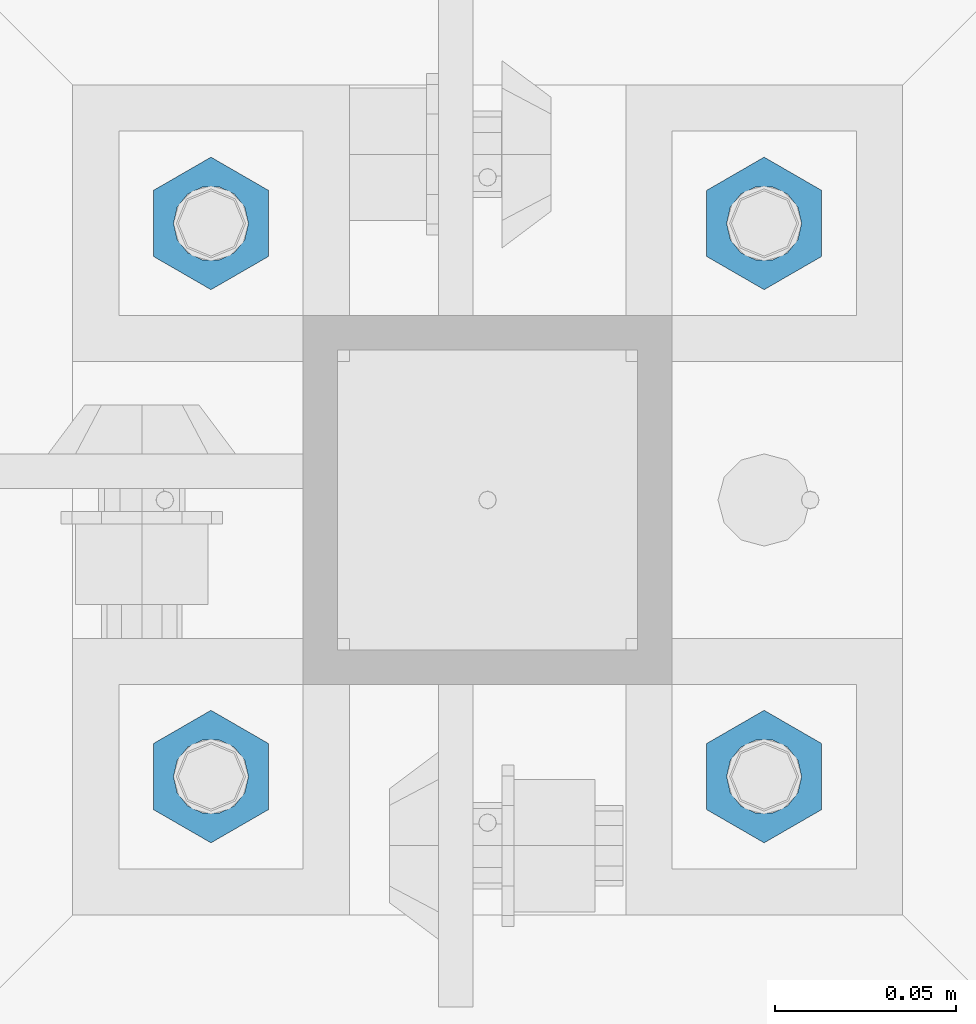
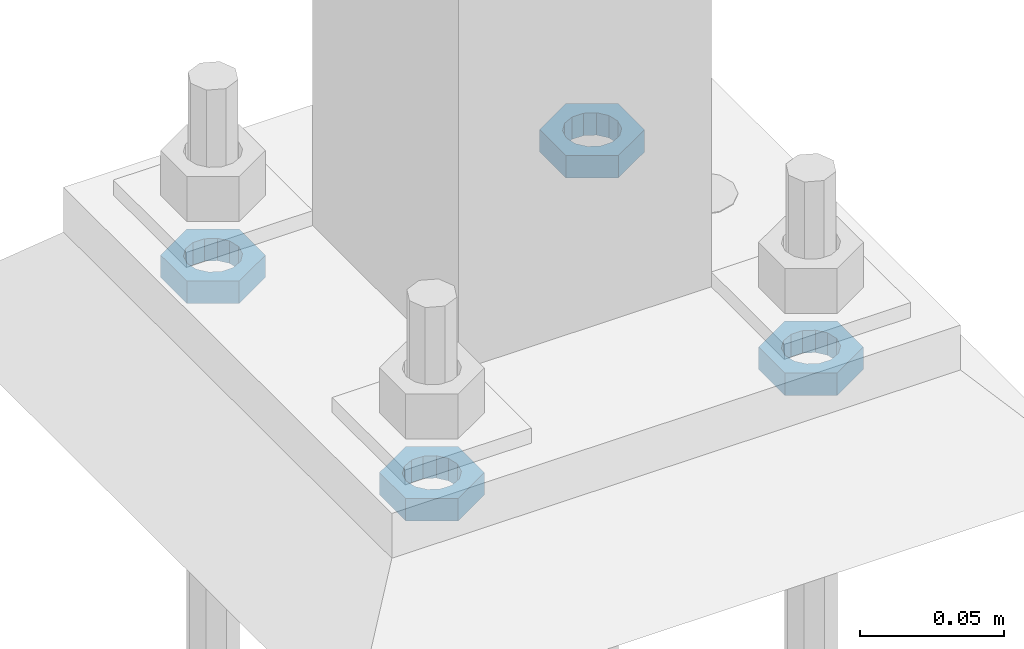
# One storey, part 2850 of 3843: 4 beams, 1 element without a shape of its own.
"""IFC2X3 building model written with IfcOpenShell, lengths in millimetres."""

from ifc_helpers import new_model, si_unit, frame, origin_with_axes, place, context, subcontext, project, spatial, faceted_brep, material, type_object, element, aggregate, save


model = new_model("IFC2X3")

# Units and contexts
model_context = context("Model", 3, precision=1e-05, world=origin_with_axes())
body_context = subcontext(model_context, "Body", "Model", "MODEL_VIEW")
ifc_project = project(units=[si_unit("LENGTHUNIT", "METRE", prefix="MILLI"), si_unit("AREAUNIT", "SQUARE_METRE"), si_unit("VOLUMEUNIT", "CUBIC_METRE"), si_unit("MASSUNIT", "GRAM", prefix="KILO"), si_unit("TIMEUNIT", "SECOND"), si_unit("PLANEANGLEUNIT", "RADIAN"), si_unit("SOLIDANGLEUNIT", "STERADIAN"), si_unit("THERMODYNAMICTEMPERATUREUNIT", "DEGREE_CELSIUS"), si_unit("LUMINOUSINTENSITYUNIT", "LUMEN")], contexts=[model_context])

# Site, building, storey
site_placement = place(None, origin_with_axes())
site = spatial("IfcSite", under=ifc_project, at=site_placement, CompositionType="ELEMENT")
building_placement = place(site_placement, origin_with_axes())
building = spatial("IfcBuilding", under=site, at=building_placement, Name="Undefined", CompositionType="ELEMENT")
storey_placement = place(building_placement, origin_with_axes())
storey = spatial("IfcBuildingStorey", under=building, at=storey_placement, Name="Undefined", CompositionType="ELEMENT", Elevation=0.0)

# Assembly, beams
assembly_placement = place(storey_placement, origin_with_axes())
assembly = element("IfcElementAssembly", 1, at=assembly_placement, inside=storey, Name="TEMPLATE", AssemblyPlace="NOTDEFINED", PredefinedType="RIGID_FRAME")
ifc_material = material(Name="STEEL/A572-50")
beam_type = type_object("IfcBeamType", Name="3/4_HALF_NUT", PredefinedType="NOTDEFINED")
beam_1_placement = place(assembly_placement, frame((38896.925, 58839.1, 30060.9), z_axis=(1.0, 0.0, 0.0), x_axis=(0.0, 0.0, -1.0)))
beam_1 = element("IfcBeam", 2, at=beam_1_placement, type_object=beam_type, material=ifc_material, Name="NUT", ObjectType="3/4_HALF_NUT", context=body_context, shape_type="Brep", body=[
    faceted_brep([(0.0, -18.2600002288818, 0.0), (0.0, -9.13000011444092, -15.8100004196167), (9.52500000000146, -9.13000011444092, -15.8100004196167), (9.52500000000146, -18.2600002288818, 0.0), (0.0, 9.13000011444092, -15.8100004196167), (9.52500000000146, 9.13000011444092, -15.8100004196167), (0.0, 18.2600002288818, 0.0), (9.52500000000146, 18.2600002288818, 0.0), (0.0, 9.13000011444092, 15.8100004196167), (9.52500000000146, 9.13000011444092, 15.8100004196167), (0.0, -9.13000011444092, 15.8100004196167), (9.52500000000146, -9.13000011444092, 15.8100004196167), (0.0, 0.0, 10.3199996948242), (0.0, 4.47768005527905, 9.29799844179797), (9.52500000000146, 4.47768005527905, 9.29799844179797), (9.52500000000146, 0.0, 10.3199996948242), (0.0, 8.06850066047627, 6.43441456490837), (9.52500000000146, 8.06850066047627, 6.43441456490837), (0.0, 10.0612557561908, 2.2964159705225), (9.52500000000146, 10.0612557561908, 2.2964159705225), (0.0, 10.0612557561908, -2.2964159705225), (9.52500000000146, 10.0612557561908, -2.2964159705225), (0.0, 8.06850066047627, -6.43441456490837), (9.52500000000146, 8.06850066047627, -6.43441456490837), (0.0, 4.47768005527905, -9.29799844179797), (9.52500000000146, 4.47768005527905, -9.29799844179797), (0.0, 0.0, -10.3199996948242), (9.52500000000146, 0.0, -10.3199996948242), (0.0, -4.47768005527905, -9.29799844179797), (9.52500000000146, -4.47768005527905, -9.29799844179797), (0.0, -8.06850066047627, -6.43441456490837), (9.52500000000146, -8.06850066047627, -6.43441456490837), (0.0, -10.0612557561908, -2.2964159705225), (9.52500000000146, -10.0612557561908, -2.2964159705225), (0.0, -10.0612557561908, 2.2964159705225), (9.52500000000146, -10.0612557561908, 2.2964159705225), (0.0, -8.06850066047627, 6.43441456490837), (9.52500000000146, -8.06850066047627, 6.43441456490837), (0.0, -4.47768005527905, 9.29799844179797), (9.52500000000146, -4.47768005527905, 9.29799844179797)], [[[0, 1, 2, 3]], [[1, 4, 5, 2]], [[4, 6, 7, 5]], [[6, 8, 9, 7]], [[8, 10, 11, 9]], [[10, 0, 3, 11]], [[12, 13, 14, 15]], [[13, 16, 17, 14]], [[16, 18, 19, 17]], [[18, 20, 21, 19]], [[20, 22, 23, 21]], [[22, 24, 25, 23]], [[24, 26, 27, 25]], [[26, 28, 29, 27]], [[28, 30, 31, 29]], [[30, 32, 33, 31]], [[32, 34, 35, 33]], [[34, 36, 37, 35]], [[36, 38, 39, 37]], [[38, 12, 15, 39]], [[5, 7, 9, 11, 3, 2], [17, 19, 21, 23, 25, 27, 29, 31, 33, 35, 37, 39, 15, 14]], [[10, 8, 6, 4, 1, 0], [38, 36, 34, 32, 30, 28, 26, 24, 22, 20, 18, 16, 13, 12]]]),
])
beam_2_placement = place(assembly_placement, frame((38896.925, 58991.5, 30060.9), z_axis=(-1.0, 0.0, 0.0), x_axis=(0.0, 0.0, -1.0)))
beam_2 = element("IfcBeam", 3, at=beam_2_placement, type_object=beam_type, material=ifc_material, Name="NUT", ObjectType="3/4_HALF_NUT", context=body_context, shape_type="Brep", body=[
    faceted_brep([(0.0, -18.2600002288818, 0.0), (0.0, -9.13000011444092, -15.8100004196167), (9.52500000000146, -9.13000011444092, -15.8100004196167), (9.52500000000146, -18.2600002288818, 0.0), (0.0, 9.13000011444092, -15.8100004196167), (9.52500000000146, 9.13000011444092, -15.8100004196167), (0.0, 18.2600002288818, 0.0), (9.52500000000146, 18.2600002288818, 0.0), (0.0, 9.13000011444092, 15.8100004196167), (9.52500000000146, 9.13000011444092, 15.8100004196167), (0.0, -9.13000011444092, 15.8100004196167), (9.52500000000146, -9.13000011444092, 15.8100004196167), (0.0, 0.0, 10.3199996948242), (0.0, 4.47768005527905, 9.29799844179797), (9.52500000000146, 4.47768005527905, 9.29799844179797), (9.52500000000146, 0.0, 10.3199996948242), (0.0, 8.06850066047627, 6.43441456490837), (9.52500000000146, 8.06850066047627, 6.43441456490837), (0.0, 10.0612557561908, 2.2964159705225), (9.52500000000146, 10.0612557561908, 2.2964159705225), (0.0, 10.0612557561908, -2.2964159705225), (9.52500000000146, 10.0612557561908, -2.2964159705225), (0.0, 8.06850066047627, -6.43441456490837), (9.52500000000146, 8.06850066047627, -6.43441456490837), (0.0, 4.47768005527905, -9.29799844179797), (9.52500000000146, 4.47768005527905, -9.29799844179797), (0.0, 0.0, -10.3199996948242), (9.52500000000146, 0.0, -10.3199996948242), (0.0, -4.47768005527905, -9.29799844179797), (9.52500000000146, -4.47768005527905, -9.29799844179797), (0.0, -8.06850066047627, -6.43441456490837), (9.52500000000146, -8.06850066047627, -6.43441456490837), (0.0, -10.0612557561908, -2.2964159705225), (9.52500000000146, -10.0612557561908, -2.2964159705225), (0.0, -10.0612557561908, 2.2964159705225), (9.52500000000146, -10.0612557561908, 2.2964159705225), (0.0, -8.06850066047627, 6.43441456490837), (9.52500000000146, -8.06850066047627, 6.43441456490837), (0.0, -4.47768005527905, 9.29799844179797), (9.52500000000146, -4.47768005527905, 9.29799844179797)], [[[0, 1, 2, 3]], [[1, 4, 5, 2]], [[4, 6, 7, 5]], [[6, 8, 9, 7]], [[8, 10, 11, 9]], [[10, 0, 3, 11]], [[12, 13, 14, 15]], [[13, 16, 17, 14]], [[16, 18, 19, 17]], [[18, 20, 21, 19]], [[20, 22, 23, 21]], [[22, 24, 25, 23]], [[24, 26, 27, 25]], [[26, 28, 29, 27]], [[28, 30, 31, 29]], [[30, 32, 33, 31]], [[32, 34, 35, 33]], [[34, 36, 37, 35]], [[36, 38, 39, 37]], [[38, 12, 15, 39]], [[5, 7, 9, 11, 3, 2], [17, 19, 21, 23, 25, 27, 29, 31, 33, 35, 37, 39, 15, 14]], [[10, 8, 6, 4, 1, 0], [38, 36, 34, 32, 30, 28, 26, 24, 22, 20, 18, 16, 13, 12]]]),
])
beam_3_placement = place(assembly_placement, frame((38744.525, 58839.1, 30060.9), z_axis=(1.0, 0.0, 0.0), x_axis=(0.0, 0.0, -1.0)))
beam_3 = element("IfcBeam", 4, at=beam_3_placement, type_object=beam_type, material=ifc_material, Name="NUT", ObjectType="3/4_HALF_NUT", context=body_context, shape_type="Brep", body=[
    faceted_brep([(0.0, -18.2600002288818, 0.0), (0.0, -9.13000011444092, -15.8100004196167), (9.52500000000146, -9.13000011444092, -15.8100004196167), (9.52500000000146, -18.2600002288818, 0.0), (0.0, 9.13000011444092, -15.8100004196167), (9.52500000000146, 9.13000011444092, -15.8100004196167), (0.0, 18.2600002288818, 0.0), (9.52500000000146, 18.2600002288818, 0.0), (0.0, 9.13000011444092, 15.8100004196167), (9.52500000000146, 9.13000011444092, 15.8100004196167), (0.0, -9.13000011444092, 15.8100004196167), (9.52500000000146, -9.13000011444092, 15.8100004196167), (0.0, 0.0, 10.3199996948242), (0.0, 4.47768005527905, 9.29799844179797), (9.52500000000146, 4.47768005527905, 9.29799844179797), (9.52500000000146, 0.0, 10.3199996948242), (0.0, 8.06850066047627, 6.43441456490837), (9.52500000000146, 8.06850066047627, 6.43441456490837), (0.0, 10.0612557561908, 2.2964159705225), (9.52500000000146, 10.0612557561908, 2.2964159705225), (0.0, 10.0612557561908, -2.2964159705225), (9.52500000000146, 10.0612557561908, -2.2964159705225), (0.0, 8.06850066047627, -6.43441456490837), (9.52500000000146, 8.06850066047627, -6.43441456490837), (0.0, 4.47768005527905, -9.29799844179797), (9.52500000000146, 4.47768005527905, -9.29799844179797), (0.0, 0.0, -10.3199996948242), (9.52500000000146, 0.0, -10.3199996948242), (0.0, -4.47768005527905, -9.29799844179797), (9.52500000000146, -4.47768005527905, -9.29799844179797), (0.0, -8.06850066047627, -6.43441456490837), (9.52500000000146, -8.06850066047627, -6.43441456490837), (0.0, -10.0612557561908, -2.2964159705225), (9.52500000000146, -10.0612557561908, -2.2964159705225), (0.0, -10.0612557561908, 2.2964159705225), (9.52500000000146, -10.0612557561908, 2.2964159705225), (0.0, -8.06850066047627, 6.43441456490837), (9.52500000000146, -8.06850066047627, 6.43441456490837), (0.0, -4.47768005527905, 9.29799844179797), (9.52500000000146, -4.47768005527905, 9.29799844179797)], [[[0, 1, 2, 3]], [[1, 4, 5, 2]], [[4, 6, 7, 5]], [[6, 8, 9, 7]], [[8, 10, 11, 9]], [[10, 0, 3, 11]], [[12, 13, 14, 15]], [[13, 16, 17, 14]], [[16, 18, 19, 17]], [[18, 20, 21, 19]], [[20, 22, 23, 21]], [[22, 24, 25, 23]], [[24, 26, 27, 25]], [[26, 28, 29, 27]], [[28, 30, 31, 29]], [[30, 32, 33, 31]], [[32, 34, 35, 33]], [[34, 36, 37, 35]], [[36, 38, 39, 37]], [[38, 12, 15, 39]], [[5, 7, 9, 11, 3, 2], [17, 19, 21, 23, 25, 27, 29, 31, 33, 35, 37, 39, 15, 14]], [[10, 8, 6, 4, 1, 0], [38, 36, 34, 32, 30, 28, 26, 24, 22, 20, 18, 16, 13, 12]]]),
])
beam_4_placement = place(assembly_placement, frame((38744.525, 58991.5, 30060.9), z_axis=(-1.0, 0.0, 0.0), x_axis=(0.0, 0.0, -1.0)))
beam_4 = element("IfcBeam", 5, at=beam_4_placement, type_object=beam_type, material=ifc_material, Name="NUT", ObjectType="3/4_HALF_NUT", context=body_context, shape_type="Brep", body=[
    faceted_brep([(0.0, -18.2600002288818, 0.0), (0.0, -9.13000011444092, -15.8100004196167), (9.52500000000146, -9.13000011444092, -15.8100004196167), (9.52500000000146, -18.2600002288818, 0.0), (0.0, 9.13000011444092, -15.8100004196167), (9.52500000000146, 9.13000011444092, -15.8100004196167), (0.0, 18.2600002288818, 0.0), (9.52500000000146, 18.2600002288818, 0.0), (0.0, 9.13000011444092, 15.8100004196167), (9.52500000000146, 9.13000011444092, 15.8100004196167), (0.0, -9.13000011444092, 15.8100004196167), (9.52500000000146, -9.13000011444092, 15.8100004196167), (0.0, 0.0, 10.3199996948242), (0.0, 4.47768005527905, 9.29799844179797), (9.52500000000146, 4.47768005527905, 9.29799844179797), (9.52500000000146, 0.0, 10.3199996948242), (0.0, 8.06850066047627, 6.43441456490837), (9.52500000000146, 8.06850066047627, 6.43441456490837), (0.0, 10.0612557561908, 2.2964159705225), (9.52500000000146, 10.0612557561908, 2.2964159705225), (0.0, 10.0612557561908, -2.2964159705225), (9.52500000000146, 10.0612557561908, -2.2964159705225), (0.0, 8.06850066047627, -6.43441456490837), (9.52500000000146, 8.06850066047627, -6.43441456490837), (0.0, 4.47768005527905, -9.29799844179797), (9.52500000000146, 4.47768005527905, -9.29799844179797), (0.0, 0.0, -10.3199996948242), (9.52500000000146, 0.0, -10.3199996948242), (0.0, -4.47768005527905, -9.29799844179797), (9.52500000000146, -4.47768005527905, -9.29799844179797), (0.0, -8.06850066047627, -6.43441456490837), (9.52500000000146, -8.06850066047627, -6.43441456490837), (0.0, -10.0612557561908, -2.2964159705225), (9.52500000000146, -10.0612557561908, -2.2964159705225), (0.0, -10.0612557561908, 2.2964159705225), (9.52500000000146, -10.0612557561908, 2.2964159705225), (0.0, -8.06850066047627, 6.43441456490837), (9.52500000000146, -8.06850066047627, 6.43441456490837), (0.0, -4.47768005527905, 9.29799844179797), (9.52500000000146, -4.47768005527905, 9.29799844179797)], [[[0, 1, 2, 3]], [[1, 4, 5, 2]], [[4, 6, 7, 5]], [[6, 8, 9, 7]], [[8, 10, 11, 9]], [[10, 0, 3, 11]], [[12, 13, 14, 15]], [[13, 16, 17, 14]], [[16, 18, 19, 17]], [[18, 20, 21, 19]], [[20, 22, 23, 21]], [[22, 24, 25, 23]], [[24, 26, 27, 25]], [[26, 28, 29, 27]], [[28, 30, 31, 29]], [[30, 32, 33, 31]], [[32, 34, 35, 33]], [[34, 36, 37, 35]], [[36, 38, 39, 37]], [[38, 12, 15, 39]], [[5, 7, 9, 11, 3, 2], [17, 19, 21, 23, 25, 27, 29, 31, 33, 35, 37, 39, 15, 14]], [[10, 8, 6, 4, 1, 0], [38, 36, 34, 32, 30, 28, 26, 24, 22, 20, 18, 16, 13, 12]]]),
])
aggregate(assembly, [beam_1, beam_2, beam_3, beam_4])

save(model, "model.ifc")
